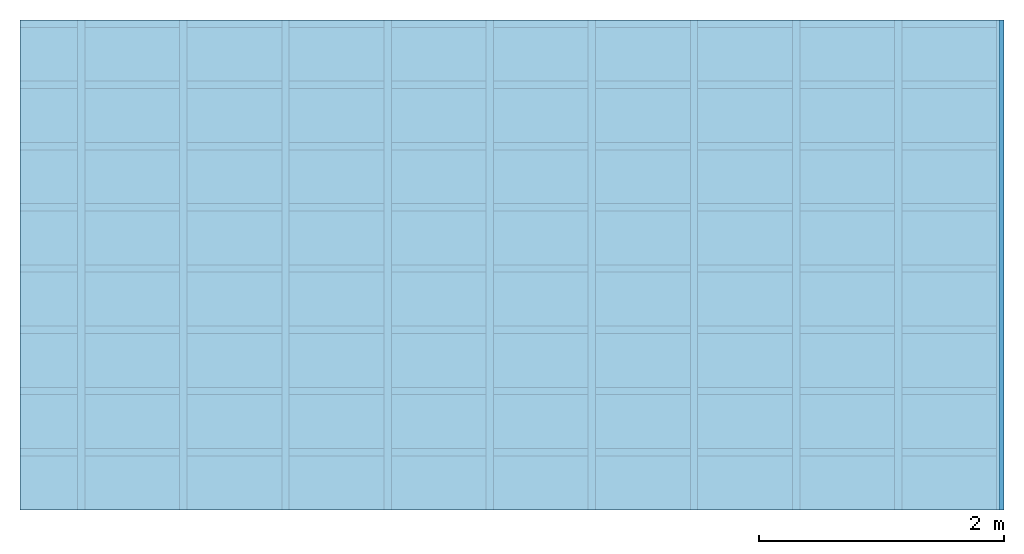
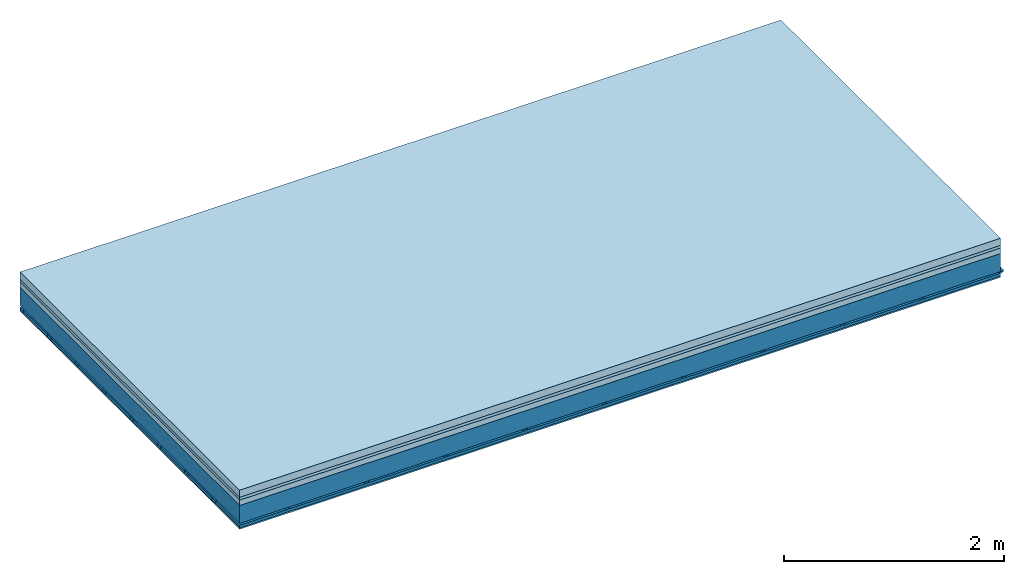
# One storey: 4 members, 4 plates, 1 element without a shape of its own.
"""IFC4 building model written with IfcOpenShell, lengths in metres."""

from ifc_helpers import new_model, si_unit, derived_unit, direction, frame, frame_2d, origin, origin_with_axes, place, context, project, spatial, polyline, rectangle, outline, extrude, material, layer, layer_set, type_object, element, aggregate, save


model = new_model("IFC4")

# Units and contexts
plan_context = context("Plan", 3, precision=1e-05, world=origin(), true_north=direction((0.0, 1.0)))
model_context = context("Model", 3, precision=1e-05, world=origin(), true_north=direction((0.0, 1.0)))
ifc_project = project(units=[si_unit("LENGTHUNIT", "METRE"), derived_unit("SOUNDPRESSUREUNIT", [(si_unit("PRESSUREUNIT", "PASCAL", prefix="MICRO"), 0)]), si_unit("ENERGYUNIT", "JOULE", prefix="MEGA"), si_unit("MASSUNIT", "GRAM", prefix="KILO"), derived_unit("THERMALTRANSMITTANCEUNIT", [(si_unit("POWERUNIT", "WATT"), 1), (si_unit("AREAUNIT", "SQUARE_METRE"), -1), (si_unit("THERMODYNAMICTEMPERATUREUNIT", "KELVIN"), -1)]), derived_unit("AREADENSITYUNIT", [(si_unit("MASSUNIT", "GRAM", prefix="KILO"), 1), (si_unit("AREAUNIT", "SQUARE_METRE"), -1)]), derived_unit("USERDEFINED", [(si_unit("ENERGYUNIT", "JOULE", prefix="MEGA"), 1), (si_unit("AREAUNIT", "SQUARE_METRE"), -1)])], contexts=[plan_context, model_context])

# Site, building, storey
site = spatial("IfcSite", under=ifc_project)
building_placement = place(None, origin())
building = spatial("IfcBuilding", under=site, at=building_placement)
storey_placement = place(building_placement, origin())
storey = spatial("IfcBuildingStorey", under=building, at=storey_placement)

# Slab, members, plates
ifc_material_1 = material(Name="Cement screed", Category="04.006")
ifc_layer_1 = layer(ifc_material_1, 0.08, Name="On-material")
ifc_material_2 = material()
ifc_layer_2 = layer(ifc_material_2, 0.03, Name="Impact sound insulation")
ifc_material_3 = material(Category="03.011")
ifc_layer_3 = layer(ifc_material_3, 0.06, Name="on Supporting structure")
ifc_layer_4 = layer(None, 0.2, Name="Supporting structure")
ifc_material_4 = material(Name="no composite action")
ifc_layer_5 = layer(ifc_material_4, 0.0, Name="Bond")
ifc_layer_6 = layer(None, 0.02, Name="Coupling")
ifc_layer_7 = layer(None, 0.03, Name="Battens / profiles")
ifc_material_5 = material(Category="03.007")
ifc_layer_8 = layer(ifc_material_5, 0.015, Name="Ceiling covering 1st layer")
ifc_material_6 = material(Name="Glued joints")
ifc_layer_9 = layer(ifc_material_6, 0.0, Name="Surface / treatment")
ifc_layer_set = layer_set([ifc_layer_1, ifc_layer_2, ifc_layer_3, ifc_layer_4, ifc_layer_5, ifc_layer_6, ifc_layer_7, ifc_layer_8, ifc_layer_9])
slab_type = type_object("IfcSlabType", Name="A1123", PredefinedType="NOTDEFINED", material=ifc_layer_set)
slab_placement = place(None, frame((0.0, 0.0, 0.0), z_axis=(0.0, 0.0, -1.0), x_axis=(1.0, 0.0, 0.0)))
slab = element("IfcSlab", 1, at=slab_placement, inside=storey, type_object=slab_type, material=ifc_layer_set, Name="Slab #1")
ifc_material_7 = material()
member_1_placement = place(slab_placement, origin())
member_1 = element("IfcMember", 2, at=member_1_placement, material=ifc_material_7, Name="Supporting structure", context=plan_context, shape_type="SweptSolid", body=[
    extrude(rectangle(XDim=1.0, YDim=0.2, at=frame_2d((0.5, 0.1), x_axis=(1.0, 0.0))), frame((0.0, 4.0, 0.17), z_axis=(0.0, -1.0, 0.0), x_axis=(1.0, 0.0, 0.0)), (0.0, 0.0, 1.0), 4.0),
    extrude(rectangle(XDim=1.0, YDim=0.2, at=frame_2d((0.5, 0.1), x_axis=(1.0, 0.0))), frame((1.0, 4.0, 0.17), z_axis=(0.0, -1.0, 0.0), x_axis=(1.0, 0.0, 0.0)), (0.0, 0.0, 1.0), 4.0),
    extrude(rectangle(XDim=1.0, YDim=0.2, at=frame_2d((0.5, 0.1), x_axis=(1.0, 0.0))), frame((2.0, 4.0, 0.17), z_axis=(0.0, -1.0, 0.0), x_axis=(1.0, 0.0, 0.0)), (0.0, 0.0, 1.0), 4.0),
    extrude(rectangle(XDim=1.0, YDim=0.2, at=frame_2d((0.5, 0.1), x_axis=(1.0, 0.0))), frame((3.0, 4.0, 0.17), z_axis=(0.0, -1.0, 0.0), x_axis=(1.0, 0.0, 0.0)), (0.0, 0.0, 1.0), 4.0),
    extrude(rectangle(XDim=1.0, YDim=0.2, at=frame_2d((0.5, 0.1), x_axis=(1.0, 0.0))), frame((4.0, 4.0, 0.17), z_axis=(0.0, -1.0, 0.0), x_axis=(1.0, 0.0, 0.0)), (0.0, 0.0, 1.0), 4.0),
    extrude(rectangle(XDim=1.0, YDim=0.2, at=frame_2d((0.5, 0.1), x_axis=(1.0, 0.0))), frame((5.0, 4.0, 0.17), z_axis=(0.0, -1.0, 0.0), x_axis=(1.0, 0.0, 0.0)), (0.0, 0.0, 1.0), 4.0),
    extrude(rectangle(XDim=1.0, YDim=0.2, at=frame_2d((0.5, 0.1), x_axis=(1.0, 0.0))), frame((6.0, 4.0, 0.17), z_axis=(0.0, -1.0, 0.0), x_axis=(1.0, 0.0, 0.0)), (0.0, 0.0, 1.0), 4.0),
    extrude(rectangle(XDim=1.0, YDim=0.2, at=frame_2d((0.5, 0.1), x_axis=(1.0, 0.0))), frame((7.0, 4.0, 0.17), z_axis=(0.0, -1.0, 0.0), x_axis=(1.0, 0.0, 0.0)), (0.0, 0.0, 1.0), 4.0),
])
ifc_material_8 = material()
member_2_placement = place(slab_placement, origin())
member_2 = element("IfcMember", 3, at=member_2_placement, material=ifc_material_8, Name="Coupling", context=plan_context, shape_type="SweptSolid", body=[
    extrude(outline(polyline([(0.0, 0.0), (0.06, 0.0), (0.04, 0.02), (0.02, 0.02), (0.0, 0.0)])), frame((0.47, 4.0, 0.37), z_axis=(0.0, -1.0, 0.0), x_axis=(1.0, 0.0, 0.0)), (0.0, 0.0, 1.0), 4.0),
    extrude(outline(polyline([(0.0, 0.0), (0.06, 0.0), (0.04, 0.02), (0.02, 0.02), (0.0, 0.0)])), frame((1.304, 4.0, 0.37), z_axis=(0.0, -1.0, 0.0), x_axis=(1.0, 0.0, 0.0)), (0.0, 0.0, 1.0), 4.0),
    extrude(outline(polyline([(0.0, 0.0), (0.06, 0.0), (0.04, 0.02), (0.02, 0.02), (0.0, 0.0)])), frame((2.138, 4.0, 0.37), z_axis=(0.0, -1.0, 0.0), x_axis=(1.0, 0.0, 0.0)), (0.0, 0.0, 1.0), 4.0),
    extrude(outline(polyline([(0.0, 0.0), (0.06, 0.0), (0.04, 0.02), (0.02, 0.02), (0.0, 0.0)])), frame((2.972, 4.0, 0.37), z_axis=(0.0, -1.0, 0.0), x_axis=(1.0, 0.0, 0.0)), (0.0, 0.0, 1.0), 4.0),
    extrude(outline(polyline([(0.0, 0.0), (0.06, 0.0), (0.04, 0.02), (0.02, 0.02), (0.0, 0.0)])), frame((3.806, 4.0, 0.37), z_axis=(0.0, -1.0, 0.0), x_axis=(1.0, 0.0, 0.0)), (0.0, 0.0, 1.0), 4.0),
    extrude(outline(polyline([(0.0, 0.0), (0.06, 0.0), (0.04, 0.02), (0.02, 0.02), (0.0, 0.0)])), frame((4.64, 4.0, 0.37), z_axis=(0.0, -1.0, 0.0), x_axis=(1.0, 0.0, 0.0)), (0.0, 0.0, 1.0), 4.0),
    extrude(outline(polyline([(0.0, 0.0), (0.06, 0.0), (0.04, 0.02), (0.02, 0.02), (0.0, 0.0)])), frame((5.474, 4.0, 0.37), z_axis=(0.0, -1.0, 0.0), x_axis=(1.0, 0.0, 0.0)), (0.0, 0.0, 1.0), 4.0),
    extrude(outline(polyline([(0.0, 0.0), (0.06, 0.0), (0.04, 0.02), (0.02, 0.02), (0.0, 0.0)])), frame((6.308, 4.0, 0.37), z_axis=(0.0, -1.0, 0.0), x_axis=(1.0, 0.0, 0.0)), (0.0, 0.0, 1.0), 4.0),
    extrude(outline(polyline([(0.0, 0.0), (0.06, 0.0), (0.04, 0.02), (0.02, 0.02), (0.0, 0.0)])), frame((7.142, 4.0, 0.37), z_axis=(0.0, -1.0, 0.0), x_axis=(1.0, 0.0, 0.0)), (0.0, 0.0, 1.0), 4.0),
    extrude(outline(polyline([(0.0, 0.0), (0.06, 0.0), (0.04, 0.02), (0.02, 0.02), (0.0, 0.0)])), frame((7.976, 4.0, 0.37), z_axis=(0.0, -1.0, 0.0), x_axis=(1.0, 0.0, 0.0)), (0.0, 0.0, 1.0), 4.0),
])
ifc_material_9 = material()
member_3_placement = place(slab_placement, origin())
member_3 = element("IfcMember", 4, at=member_3_placement, material=ifc_material_9, Name="Battens / profiles", context=plan_context, shape_type="SweptSolid", body=[
    extrude(rectangle(XDim=0.06, YDim=0.03, at=frame_2d((0.03, 0.015), x_axis=(1.0, 0.0))), frame((0.0, 0.0, 0.39), z_axis=(1.0, 0.0, 0.0), x_axis=(0.0, 1.0, 0.0)), (0.0, 0.0, 1.0), 8.0),
    extrude(rectangle(XDim=0.06, YDim=0.03, at=frame_2d((0.03, 0.015), x_axis=(1.0, 0.0))), frame((0.0, 0.5, 0.39), z_axis=(1.0, 0.0, 0.0), x_axis=(0.0, 1.0, 0.0)), (0.0, 0.0, 1.0), 8.0),
    extrude(rectangle(XDim=0.06, YDim=0.03, at=frame_2d((0.03, 0.015), x_axis=(1.0, 0.0))), frame((0.0, 1.0, 0.39), z_axis=(1.0, 0.0, 0.0), x_axis=(0.0, 1.0, 0.0)), (0.0, 0.0, 1.0), 8.0),
    extrude(rectangle(XDim=0.06, YDim=0.03, at=frame_2d((0.03, 0.015), x_axis=(1.0, 0.0))), frame((0.0, 1.5, 0.39), z_axis=(1.0, 0.0, 0.0), x_axis=(0.0, 1.0, 0.0)), (0.0, 0.0, 1.0), 8.0),
    extrude(rectangle(XDim=0.06, YDim=0.03, at=frame_2d((0.03, 0.015), x_axis=(1.0, 0.0))), frame((0.0, 2.0, 0.39), z_axis=(1.0, 0.0, 0.0), x_axis=(0.0, 1.0, 0.0)), (0.0, 0.0, 1.0), 8.0),
    extrude(rectangle(XDim=0.06, YDim=0.03, at=frame_2d((0.03, 0.015), x_axis=(1.0, 0.0))), frame((0.0, 2.5, 0.39), z_axis=(1.0, 0.0, 0.0), x_axis=(0.0, 1.0, 0.0)), (0.0, 0.0, 1.0), 8.0),
    extrude(rectangle(XDim=0.06, YDim=0.03, at=frame_2d((0.03, 0.015), x_axis=(1.0, 0.0))), frame((0.0, 3.0, 0.39), z_axis=(1.0, 0.0, 0.0), x_axis=(0.0, 1.0, 0.0)), (0.0, 0.0, 1.0), 8.0),
    extrude(rectangle(XDim=0.06, YDim=0.03, at=frame_2d((0.03, 0.015), x_axis=(1.0, 0.0))), frame((0.0, 3.5, 0.39), z_axis=(1.0, 0.0, 0.0), x_axis=(0.0, 1.0, 0.0)), (0.0, 0.0, 1.0), 8.0),
])
ifc_material_10 = material()
member_4_placement = place(slab_placement, origin())
member_4 = element("IfcMember", 5, at=member_4_placement, material=ifc_material_10, Name="Cavity", context=plan_context, shape_type="SweptSolid", body=[
    extrude(rectangle(XDim=0.44, YDim=0.03, at=frame_2d((0.22, 0.015), x_axis=(1.0, 0.0))), frame((0.0, 0.06, 0.39), z_axis=(1.0, 0.0, 0.0), x_axis=(0.0, 1.0, 0.0)), (0.0, 0.0, 1.0), 8.0),
    extrude(rectangle(XDim=0.44, YDim=0.03, at=frame_2d((0.22, 0.015), x_axis=(1.0, 0.0))), frame((0.0, 0.56, 0.39), z_axis=(1.0, 0.0, 0.0), x_axis=(0.0, 1.0, 0.0)), (0.0, 0.0, 1.0), 8.0),
    extrude(rectangle(XDim=0.44, YDim=0.03, at=frame_2d((0.22, 0.015), x_axis=(1.0, 0.0))), frame((0.0, 1.06, 0.39), z_axis=(1.0, 0.0, 0.0), x_axis=(0.0, 1.0, 0.0)), (0.0, 0.0, 1.0), 8.0),
    extrude(rectangle(XDim=0.44, YDim=0.03, at=frame_2d((0.22, 0.015), x_axis=(1.0, 0.0))), frame((0.0, 1.56, 0.39), z_axis=(1.0, 0.0, 0.0), x_axis=(0.0, 1.0, 0.0)), (0.0, 0.0, 1.0), 8.0),
    extrude(rectangle(XDim=0.44, YDim=0.03, at=frame_2d((0.22, 0.015), x_axis=(1.0, 0.0))), frame((0.0, 2.06, 0.39), z_axis=(1.0, 0.0, 0.0), x_axis=(0.0, 1.0, 0.0)), (0.0, 0.0, 1.0), 8.0),
    extrude(rectangle(XDim=0.44, YDim=0.03, at=frame_2d((0.22, 0.015), x_axis=(1.0, 0.0))), frame((0.0, 2.56, 0.39), z_axis=(1.0, 0.0, 0.0), x_axis=(0.0, 1.0, 0.0)), (0.0, 0.0, 1.0), 8.0),
    extrude(rectangle(XDim=0.44, YDim=0.03, at=frame_2d((0.22, 0.015), x_axis=(1.0, 0.0))), frame((0.0, 3.06, 0.39), z_axis=(1.0, 0.0, 0.0), x_axis=(0.0, 1.0, 0.0)), (0.0, 0.0, 1.0), 8.0),
    extrude(rectangle(XDim=0.44, YDim=0.03, at=frame_2d((0.22, 0.015), x_axis=(1.0, 0.0))), frame((0.0, 3.56, 0.39), z_axis=(1.0, 0.0, 0.0), x_axis=(0.0, 1.0, 0.0)), (0.0, 0.0, 1.0), 8.0),
])
plate_1_placement = place(slab_placement, origin())
plate_1 = element("IfcPlate", 6, at=plate_1_placement, material=ifc_material_1, Name="On-material", context=plan_context, shape_type="SweptSolid", body=[
    extrude(rectangle(XDim=8.0, YDim=4.0, at=frame_2d((4.0, 2.0), x_axis=(1.0, 0.0))), origin_with_axes(), (0.0, 0.0, 1.0), 0.08),
])
plate_2_placement = place(slab_placement, origin())
plate_2 = element("IfcPlate", 7, at=plate_2_placement, material=ifc_material_2, Name="Impact sound insulation", context=plan_context, shape_type="SweptSolid", body=[
    extrude(rectangle(XDim=8.0, YDim=4.0, at=frame_2d((4.0, 2.0), x_axis=(1.0, 0.0))), frame((0.0, 0.0, 0.08), z_axis=(0.0, 0.0, 1.0), x_axis=(1.0, 0.0, 0.0)), (0.0, 0.0, 1.0), 0.03),
])
plate_3_placement = place(slab_placement, origin())
plate_3 = element("IfcPlate", 8, at=plate_3_placement, material=ifc_material_3, Name="on Supporting structure", context=plan_context, shape_type="SweptSolid", body=[
    extrude(rectangle(XDim=8.0, YDim=4.0, at=frame_2d((4.0, 2.0), x_axis=(1.0, 0.0))), frame((0.0, 0.0, 0.11), z_axis=(0.0, 0.0, 1.0), x_axis=(1.0, 0.0, 0.0)), (0.0, 0.0, 1.0), 0.06),
])
plate_4_placement = place(slab_placement, origin())
plate_4 = element("IfcPlate", 9, at=plate_4_placement, material=ifc_material_5, Name="Ceiling covering 1st layer", context=plan_context, shape_type="SweptSolid", body=[
    extrude(rectangle(XDim=8.0, YDim=4.0, at=frame_2d((4.0, 2.0), x_axis=(1.0, 0.0))), frame((0.0, 0.0, 0.42), z_axis=(0.0, 0.0, 1.0), x_axis=(1.0, 0.0, 0.0)), (0.0, 0.0, 1.0), 0.015),
])
aggregate(slab, [plate_1, plate_2, plate_3, member_1, member_2, member_3, member_4, plate_4])

save(model, "model.ifc")
